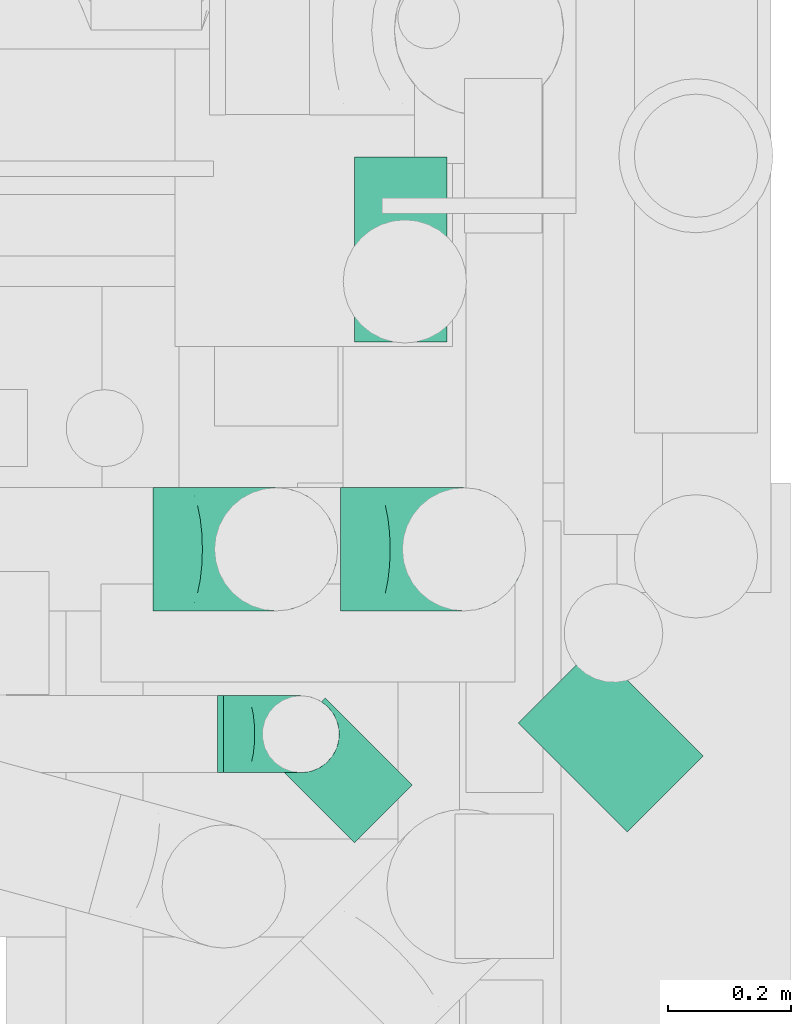
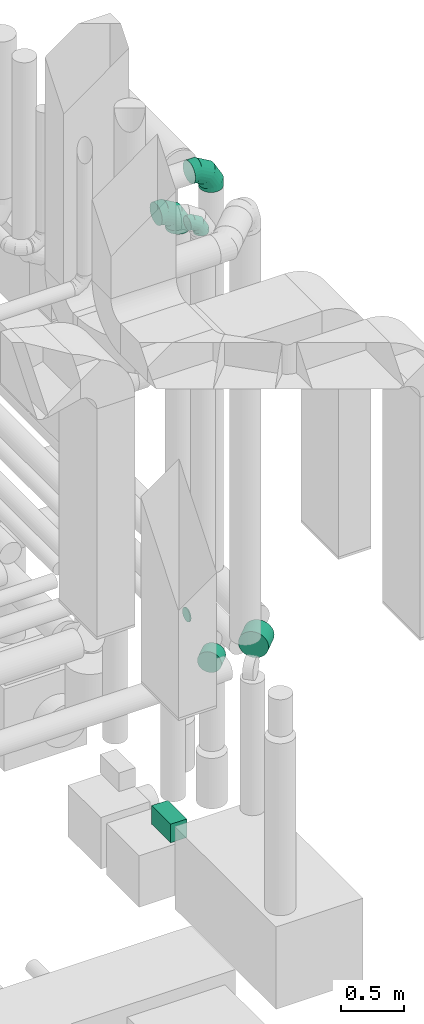
# One storey, part 301 of 337: 4 flow segments, 3 flow fittings.
"""IFC2X3 building model written with IfcOpenShell, lengths in millimetres."""

import ifcopenshell
import ifcopenshell.guid

model = None  # the IFC model being written
_history = None  # IfcOwnerHistory: only IFC2X3 demands one
_inside = {}  # id of a spatial element -> (the spatial element, [elements in it])
_under = {}  # id of a project, library or spatial element -> (it, [spatial elements below it])
_declared = {}  # id of a project -> (the project, [libraries it declares])
_typed = {}  # id of a type object -> (the type object, [elements of that type])
_made_of = {}  # id of a material, layer set ... -> (it, [elements and type objects made of it])


def new_model(schema):
    """Start an empty IFC model of exactly this schema.

    Asked for "IFC4X3", IfcOpenShell would pick the latest addendum, in which some entities
    have other attributes; the version numbers below select the first issue.
    IFC2X3 requires an IfcOwnerHistory on every rooted entity: one is made here for all.
    """
    global model, _history
    if schema == "IFC4X3":
        model = ifcopenshell.file(schema_version=(4, 3, 0, 0))
    else:
        model = ifcopenshell.file(schema=schema)
    _inside.clear()
    _under.clear()
    _declared.clear()
    _typed.clear()
    _made_of.clear()
    _history = None
    if model.schema == "IFC2X3":
        org = make("IfcOrganization", Name="unknown")
        user = make(
            "IfcPersonAndOrganization",
            ThePerson=make("IfcPerson", FamilyName="unknown"),
            TheOrganization=org,
        )
        app = make(
            "IfcApplication",
            ApplicationDeveloper=org,
            Version="unknown",
            ApplicationFullName="unknown",
            ApplicationIdentifier="unknown",
        )
        _history = make(
            "IfcOwnerHistory",
            OwningUser=user,
            OwningApplication=app,
            ChangeAction="ADDED",
            CreationDate=0,
        )
    return model


def make(cls, **values):
    """One entity of the class cls with the attributes given. An attribute that is None is left unset."""
    return model.create_entity(
        cls, **{name: value for name, value in values.items() if value is not None}
    )


def entity(cls, *values):
    """Any entity or typed value of the class cls, its attributes in the order of the schema. None: left unset."""
    e = model.create_entity(cls)
    for i, value in enumerate(values):
        if value is not None:
            e[i] = value
    return e


def rooted(cls, **values):
    """An entity with a GlobalId (a new one), such as an element, a storey or a relation."""
    return make(cls, GlobalId=ifcopenshell.guid.new(), OwnerHistory=_history, **values)


def si_unit(unit_type, name, prefix=None):
    """IfcSIUnit, for example si_unit("LENGTHUNIT", "METRE", prefix="MILLI")."""
    return make("IfcSIUnit", UnitType=unit_type, Prefix=prefix, Name=name)


def converted_unit(unit_type, name, factor, base, dimensions=None, offset=None):
    """IfcConversionBasedUnit, such as the inch: factor (a typed value) times the base unit."""
    return make(
        "IfcConversionBasedUnit"
        if offset is None
        else "IfcConversionBasedUnitWithOffset",
        ConversionOffset=offset,
        Dimensions=None
        if dimensions is None
        else entity("IfcDimensionalExponents", *dimensions),
        UnitType=unit_type,
        Name=name,
        ConversionFactor=make(
            "IfcMeasureWithUnit", ValueComponent=factor, UnitComponent=base
        ),
    )


def derived_unit(unit_type, elements):
    """IfcDerivedUnit: a product of units, each with its exponent."""
    return make(
        "IfcDerivedUnit",
        Elements=[
            make("IfcDerivedUnitElement", Unit=unit, Exponent=power)
            for unit, power in elements
        ],
        UnitType=unit_type,
    )


def assignment(units):
    """IfcUnitAssignment: the units of a project."""
    return None if units is None else make("IfcUnitAssignment", Units=units)


def point(xyz):
    """IfcCartesianPoint."""
    return None if xyz is None else make("IfcCartesianPoint", Coordinates=xyz)


def direction(xyz):
    """IfcDirection."""
    return None if xyz is None else make("IfcDirection", DirectionRatios=xyz)


def frame(location, z_axis=None, x_axis=None):
    """IfcAxis2Placement3D, a coordinate frame: its origin and axes. An axis left out is left unset."""
    return make(
        "IfcAxis2Placement3D",
        Location=point(location),
        Axis=direction(z_axis),
        RefDirection=direction(x_axis),
    )


def frame_2d(location, x_axis=None):
    """IfcAxis2Placement2D, a coordinate frame in the plane: its origin and x axis."""
    return make(
        "IfcAxis2Placement2D", Location=point(location), RefDirection=direction(x_axis)
    )


def origin():
    """The frame at (0, 0, 0) with its axes left unset."""
    return frame((0.0, 0.0, 0.0))


def origin_2d_with_axis():
    """The frame at (0, 0) in the plane with the x axis (1, 0) written out."""
    return frame_2d((0.0, 0.0), x_axis=(1.0, 0.0))


def place(relative_to, where):
    """IfcLocalPlacement: puts the frame where relative to a parent placement (None: the world)."""
    return make(
        "IfcLocalPlacement", PlacementRelTo=relative_to, RelativePlacement=where
    )


def context(
    kind, dimensions, precision=None, world=None, true_north=None, identifier=None
):
    """IfcGeometricRepresentationContext, for example the 3D "Model" context."""
    return make(
        "IfcGeometricRepresentationContext",
        ContextIdentifier=identifier,
        ContextType=kind,
        CoordinateSpaceDimension=dimensions,
        Precision=precision,
        WorldCoordinateSystem=world,
        TrueNorth=true_north,
    )


def subcontext(parent, identifier, kind, view, scale=None):
    """IfcGeometricRepresentationSubContext, for example "Body" below "Model"."""
    return make(
        "IfcGeometricRepresentationSubContext",
        ContextIdentifier=identifier,
        ContextType=kind,
        ParentContext=parent,
        TargetScale=scale,
        TargetView=view,
    )


def project(units=None, contexts=None):
    """IfcProject with its units and contexts."""
    return rooted(
        "IfcProject",
        Name="project",
        RepresentationContexts=contexts,
        UnitsInContext=assignment(units),
    )


def spatial(cls, under=None, at=None, **own):
    """A site, building, storey or space (cls), placed at a placement, below another one or the project."""
    s = rooted(cls, ObjectPlacement=at, **own)
    if under is not None:
        _under.setdefault(under.id(), (under, []))[1].append(s)
    return s


def profile(cls, at=None, kind="AREA", **sizes):
    """A parametric profile (cls). Its sizes go by their IFC names, for example OverallWidth=200.0."""
    return make(cls, ProfileType=kind, Position=at, **sizes)


def rectangle(**sizes):
    """IfcRectangleProfileDef."""
    return profile("IfcRectangleProfileDef", **sizes)


def circle(**sizes):
    """IfcCircleProfileDef."""
    return profile("IfcCircleProfileDef", **sizes)


def extrude(swept, where, along, depth):
    """IfcExtrudedAreaSolid: the profile swept, set in the frame where, extruded along a direction by depth."""
    return make(
        "IfcExtrudedAreaSolid",
        SweptArea=swept,
        Position=where,
        ExtrudedDirection=direction(along),
        Depth=depth,
    )


def faces_of(points, faces, orient=None, outer=None):
    """IfcFace entities. A face is a list of loops; a loop is a list of indices into points, from 0.

    orient and outer hold one flag for each loop. By default every Orientation is true, the
    first loop of a face is its IfcFaceOuterBound and the others are IfcFaceBound.
    """
    made = []
    for i, loops in enumerate(faces):
        bounds = []
        for j, loop in enumerate(loops):
            is_outer = j == 0 if outer is None else outer[i][j]
            bounds.append(
                make(
                    "IfcFaceOuterBound" if is_outer else "IfcFaceBound",
                    Bound=make("IfcPolyLoop", Polygon=[points[k] for k in loop]),
                    Orientation=True if orient is None else orient[i][j],
                )
            )
        made.append(make("IfcFace", Bounds=bounds))
    return made


def faceted_brep(points, faces, orient=None, outer=None, voids=None):
    """IfcFacetedBrep: a solid bounded by flat faces; with voids (closed shells), ...WithVoids."""
    shared = [point(p) for p in points]
    hull = make("IfcClosedShell", CfsFaces=faces_of(shared, faces, orient, outer))
    if voids is None:
        return make("IfcFacetedBrep", Outer=hull)
    return make(
        "IfcFacetedBrepWithVoids",
        Outer=hull,
        Voids=[
            make(cls, CfsFaces=faces_of(shared, fs, o, b)) for cls, fs, o, b in voids
        ],
    )


def shape(context_of_items, identifier, shape_type, items):
    """IfcShapeRepresentation: the items that make up one representation, for example the "Body"."""
    return make(
        "IfcShapeRepresentation",
        ContextOfItems=context_of_items,
        RepresentationIdentifier=identifier,
        RepresentationType=shape_type,
        Items=items,
    )


def source(mapping_origin, context_of_items, identifier, shape_type, items):
    """IfcRepresentationMap: a shape defined once, which mapped items show again and again."""
    return make(
        "IfcRepresentationMap",
        MappingOrigin=mapping_origin,
        MappedRepresentation=shape(context_of_items, identifier, shape_type, items),
    )


def transform(
    local_origin,
    x_axis=None,
    y_axis=None,
    z_axis=None,
    scale=None,
    scale2=None,
    scale3=None,
    uniform=True,
):
    """IfcCartesianTransformationOperator3D, or its non-uniform kind. x_axis, y_axis, z_axis: its Axis1, 2, 3."""
    if uniform:
        return make(
            "IfcCartesianTransformationOperator3D",
            Axis1=direction(x_axis),
            Axis2=direction(y_axis),
            LocalOrigin=point(local_origin),
            Scale=scale,
            Axis3=direction(z_axis),
        )
    return make(
        "IfcCartesianTransformationOperator3DnonUniform",
        Axis1=direction(x_axis),
        Axis2=direction(y_axis),
        LocalOrigin=point(local_origin),
        Scale=scale,
        Axis3=direction(z_axis),
        Scale2=scale2,
        Scale3=scale3,
    )


def mapped(mapping_source, mapping_target):
    """IfcMappedItem: shows the shape of a source again, moved by a transform."""
    return make(
        "IfcMappedItem", MappingSource=mapping_source, MappingTarget=mapping_target
    )


def material(Name=None, Category=None):
    """IfcMaterial."""
    return make("IfcMaterial", Name=Name, Category=Category)


def made_of(thing, what):
    """Note that an element or type object is made of a material, layer set ...; save() writes the relation."""
    if what is not None:
        _made_of.setdefault(what.id(), (what, []))[1].append(thing)
    return thing


def type_object(cls, material=None, **own):
    """A type object (cls), such as IfcWallType, which elements share."""
    return made_of(rooted(cls, **own), material)


def type_shapes(of_type, sources):
    """Give a type object the sources (RepresentationMaps) that its elements show as mapped items."""
    of_type.RepresentationMaps = sources


def element(
    cls,
    number,
    at=None,
    inside=None,
    cuts=None,
    type_object=None,
    material=None,
    context=None,
    identifier="Body",
    shape_type=None,
    held_by="IfcProductDefinitionShape",
    body=None,
    shapes=None,
    **own,
):
    """One element of the class cls, such as IfcWall. Its Tag is "e" and its number.

    at: its placement. inside: the storey or other place that contains it. cuts: it is an
    opening in that element (IfcRelVoidsElement). A single representation is given by context,
    identifier, shape_type and body (its items); several are given by shapes. held_by: the class
    of the entity that holds the representations. save() writes the other relations.
    """
    e = rooted(cls, Tag="e%d" % number, ObjectPlacement=at, **own)
    if body is not None:
        shapes = [shape(context, identifier, shape_type, body)]
    if shapes is not None:
        e.Representation = make(held_by, Representations=shapes)
    if inside is not None:
        _inside.setdefault(inside.id(), (inside, []))[1].append(e)
    if cuts is not None:
        rooted(
            "IfcRelVoidsElement", RelatingBuildingElement=cuts, RelatedOpeningElement=e
        )
    if type_object is not None:
        _typed.setdefault(type_object.id(), (type_object, []))[1].append(e)
    return made_of(e, material)


def aggregate(whole, parts):
    """IfcRelAggregates: a whole, such as a stair, and the parts it consists of."""
    return rooted("IfcRelAggregates", RelatingObject=whole, RelatedObjects=parts)


def save(model, path):
    """Write the relations noted so far, then the file.

    IfcRelAggregates (storeys below a building ...), IfcRelContainedInSpatialStructure (elements
    in a storey), IfcRelDefinesByType, IfcRelAssociatesMaterial and IfcRelDeclares: one each for
    every whole, place, type object, material and project.
    """
    for whole, parts in _under.values():
        aggregate(whole, parts)
    for where, things in _inside.values():
        rooted(
            "IfcRelContainedInSpatialStructure",
            RelatedElements=things,
            RelatingStructure=where,
        )
    for kind, things in _typed.values():
        rooted("IfcRelDefinesByType", RelatedObjects=things, RelatingType=kind)
    for what, things in _made_of.values():
        rooted("IfcRelAssociatesMaterial", RelatedObjects=things, RelatingMaterial=what)
    for by, libraries in _declared.values():
        rooted("IfcRelDeclares", RelatingContext=by, RelatedDefinitions=libraries)
    model.write(path)


model = new_model("IFC2X3")

# Units and contexts
model_context = context("Model", 3, precision=0.01, world=origin(), true_north=direction((6.12303176911189e-17, 1.0)))
body_context = subcontext(model_context, "Body", "Model", "MODEL_VIEW")
ifc_project = project(units=[si_unit("LENGTHUNIT", "METRE", prefix="MILLI"), si_unit("AREAUNIT", "SQUARE_METRE"), si_unit("VOLUMEUNIT", "CUBIC_METRE"), converted_unit("PLANEANGLEUNIT", "DEGREE", entity("IfcRatioMeasure", 0.0174532925199433), si_unit("PLANEANGLEUNIT", "RADIAN"), dimensions=[0, 0, 0, 0, 0, 0, 0]), si_unit("MASSUNIT", "GRAM", prefix="KILO"), derived_unit("MASSDENSITYUNIT", [(si_unit("MASSUNIT", "GRAM", prefix="KILO"), 1), (si_unit("LENGTHUNIT", "METRE"), -3)]), derived_unit("MOMENTOFINERTIAUNIT", [(si_unit("LENGTHUNIT", "METRE"), 4)]), si_unit("TIMEUNIT", "SECOND"), si_unit("FREQUENCYUNIT", "HERTZ"), si_unit("THERMODYNAMICTEMPERATUREUNIT", "DEGREE_CELSIUS"), derived_unit("THERMALTRANSMITTANCEUNIT", [(si_unit("MASSUNIT", "GRAM", prefix="KILO"), 1), (si_unit("THERMODYNAMICTEMPERATUREUNIT", "KELVIN"), -1), (si_unit("TIMEUNIT", "SECOND"), -3)]), derived_unit("VOLUMETRICFLOWRATEUNIT", [(si_unit("LENGTHUNIT", "METRE"), 3), (si_unit("TIMEUNIT", "SECOND"), -1)]), derived_unit("MASSFLOWRATEUNIT", [(si_unit("MASSUNIT", "GRAM", prefix="KILO"), 1), (si_unit("TIMEUNIT", "SECOND"), -1)]), derived_unit("ROTATIONALFREQUENCYUNIT", [(si_unit("TIMEUNIT", "SECOND"), -1)]), si_unit("ELECTRICCURRENTUNIT", "AMPERE"), si_unit("ELECTRICVOLTAGEUNIT", "VOLT"), si_unit("POWERUNIT", "WATT"), si_unit("FORCEUNIT", "NEWTON", prefix="KILO"), si_unit("ILLUMINANCEUNIT", "LUX"), si_unit("LUMINOUSFLUXUNIT", "LUMEN"), si_unit("LUMINOUSINTENSITYUNIT", "CANDELA"), derived_unit("USERDEFINED", [(si_unit("MASSUNIT", "GRAM", prefix="KILO"), -1), (si_unit("LENGTHUNIT", "METRE"), -2), (si_unit("TIMEUNIT", "SECOND"), 3), (si_unit("LUMINOUSFLUXUNIT", "LUMEN"), 1)]), derived_unit("LINEARVELOCITYUNIT", [(si_unit("LENGTHUNIT", "METRE"), 1), (si_unit("TIMEUNIT", "SECOND"), -1)]), si_unit("PRESSUREUNIT", "PASCAL"), derived_unit("USERDEFINED", [(si_unit("LENGTHUNIT", "METRE"), -2), (si_unit("MASSUNIT", "GRAM", prefix="KILO"), 1), (si_unit("TIMEUNIT", "SECOND"), -2)]), derived_unit("LINEARFORCEUNIT", [(si_unit("MASSUNIT", "GRAM", prefix="KILO"), 1), (si_unit("LENGTHUNIT", "METRE"), 1), (si_unit("TIMEUNIT", "SECOND"), -2), (si_unit("LENGTHUNIT", "METRE"), -1)]), derived_unit("PLANARFORCEUNIT", [(si_unit("MASSUNIT", "GRAM", prefix="KILO"), 1), (si_unit("LENGTHUNIT", "METRE"), 1), (si_unit("TIMEUNIT", "SECOND"), -2), (si_unit("LENGTHUNIT", "METRE"), -2)])], contexts=[model_context])

# Site, building, storey
site_placement = place(None, origin())
site = spatial("IfcSite", under=ifc_project, at=site_placement, CompositionType="ELEMENT")
building_placement = place(site_placement, origin())
building = spatial("IfcBuilding", under=site, at=building_placement, CompositionType="ELEMENT")
storey_placement = place(building_placement, origin())
storey = spatial("IfcBuildingStorey", under=building, at=storey_placement, CompositionType="ELEMENT", Elevation=0.0)

# Flow segments
duct_segment_type_1 = type_object("IfcDuctSegmentType", PredefinedType="NOTDEFINED")
flow_segment_1_placement = place(storey_placement, frame((72540.93, 9684.11, 28970.0)))
element("IfcFlowSegment", 1, at=flow_segment_1_placement, inside=storey, type_object=duct_segment_type_1, context=body_context, shape_type="SweptSolid", body=[
    extrude(rectangle(XDim=300.000000000001, YDim=150.000000000001, at=origin_2d_with_axis()), frame((75.0, 150.0, 0.0), z_axis=(0.0, 0.0, 1.0), x_axis=(0.0, 1.0, 0.0)), (0.0, 0.0, 1.0), 180.000000000011),
])
duct_segment_type_2 = type_object("IfcDuctSegmentType", PredefinedType="NOTDEFINED")
flow_segment_2_placement = place(storey_placement, frame((72318.8, 8983.65, 31585.9)))
element("IfcFlowSegment", 2, at=flow_segment_2_placement, inside=storey, type_object=duct_segment_type_2, context=body_context, shape_type="SweptSolid", body=[
    extrude(circle(Radius=62.5, at=origin_2d_with_axis()), frame((0.0, 64.1, 64.1), z_axis=(1.0, 0.0, 0.0), x_axis=(0.0, 1.0, 0.0)), (0.0, 0.0, 1.0), 10.0000000000151),
])
flow_segment_3_placement = place(storey_placement, frame((72397.91, 8869.86, 31098.4)))
element("IfcFlowSegment", 3, at=flow_segment_3_placement, inside=storey, type_object=duct_segment_type_2, context=body_context, shape_type="SweptSolid", body=[
    extrude(circle(Radius=100.0, at=origin_2d_with_axis()), frame((72.31, 72.31, 101.6), z_axis=(0.707106781186654, 0.707106781186441, 0.0), x_axis=(-0.707106781186441, 0.707106781186654, 0.0)), (0.0, 0.0, 1.0), 132.703620410378),
])
flow_segment_4_placement = place(storey_placement, frame((72805.28, 8887.54, 31073.4)))
element("IfcFlowSegment", 4, at=flow_segment_4_placement, inside=storey, type_object=duct_segment_type_2, context=body_context, shape_type="SweptSolid", body=[
    extrude(circle(Radius=125.0, at=origin_2d_with_axis()), frame((89.98, 89.98, 126.6), z_axis=(0.7071067811867, 0.707106781186395, 0.0), x_axis=(-0.707106781186395, 0.7071067811867, 0.0)), (0.0, 0.0, 1.0), 174.407375131986),
])

# Flow fittings
ifc_material = material()
duct_fitting_type_1 = type_object("IfcDuctFittingType", PredefinedType="NOTDEFINED", material=ifc_material)
shared_shape_1 = source(origin(), body_context, "Body", "Brep", [
    faceted_brep([(-200.0, 0.0, -100.0), (-200.0, -25.88, -96.59), (-200.0, -50.0, -86.6), (-200.0, -70.71, -70.71), (-200.0, -86.6, -50.0), (-200.0, -96.59, -25.88), (-200.0, -100.0, 0.0), (-200.0, -96.59, 25.88), (-200.0, -86.6, 50.0), (-200.0, -70.71, 70.71), (-200.0, -50.0, 86.6), (-200.0, -25.88, 96.59), (-200.0, 0.0, 100.0), (-200.0, 25.88, 96.59), (-200.0, 50.0, 86.6), (-200.0, 70.71, 70.71), (-200.0, 86.6, 50.0), (-200.0, 96.59, 25.88), (-200.0, 100.0, 0.0), (-200.0, 96.59, -25.88), (-200.0, 86.6, -50.0), (-200.0, 70.71, -70.71), (-200.0, 50.0, -86.6), (-200.0, 25.88, -96.59), (-153.35, 25.88, 96.59), (-159.81, 50.0, 86.6), (-146.41, 0.0, 100.0), (-165.36, 70.71, 70.71), (-172.29, 96.59, 25.88), (-173.21, 100.0, 0.0), (-169.62, 86.6, 50.0), (-169.62, 86.6, -50.0), (-165.36, 70.71, -70.71), (-172.29, 96.59, -25.88), (-153.35, 25.88, -96.59), (-146.41, 0.0, -100.0), (-159.81, 50.0, -86.6), (-139.48, -25.88, -96.59), (-133.01, -50.0, -86.6), (-127.46, -70.71, -70.71), (-123.21, -86.6, -50.0), (-120.53, -96.59, -25.88), (-119.62, -100.0, 0.0), (-120.53, -96.59, 25.88), (-123.21, -86.6, 50.0), (-127.46, -70.71, 70.71), (-133.01, -50.0, 86.6), (-139.48, -25.88, 96.59), (-72.54, 72.54, 96.59), (-90.19, 90.19, 86.6), (-53.59, 53.59, 100.0), (-105.35, 105.35, 70.71), (-116.99, 116.99, 50.0), (-124.3, 124.3, 25.88), (-126.79, 126.79, 0.0), (-124.3, 124.3, -25.88), (-116.99, 116.99, -50.0), (-105.35, 105.35, -70.71), (-72.54, 72.54, -96.59), (-53.59, 53.59, -100.0), (-90.19, 90.19, -86.6), (-34.64, 34.64, -96.59), (-16.99, 16.99, -86.6), (-1.83, 1.83, -70.71), (9.81, -9.81, -50.0), (17.12, -17.12, -25.88), (19.62, -19.62, 0.0), (17.12, -17.12, 25.88), (9.81, -9.81, 50.0), (-1.83, 1.83, 70.71), (-16.99, 16.99, 86.6), (-34.64, 34.64, 96.59), (-25.88, 153.35, 96.59), (-50.0, 159.81, 86.6), (0.0, 146.41, 100.0), (-70.71, 165.36, 70.71), (-86.6, 169.62, 50.0), (-96.59, 172.29, 25.88), (-100.0, 173.21, 0.0), (-96.59, 172.29, -25.88), (-86.6, 169.62, -50.0), (-70.71, 165.36, -70.71), (-25.88, 153.35, -96.59), (0.0, 146.41, -100.0), (-50.0, 159.81, -86.6), (25.88, 139.48, -96.59), (50.0, 133.01, -86.6), (70.71, 127.46, -70.71), (86.6, 123.21, -50.0), (96.59, 120.53, -25.88), (100.0, 119.62, 0.0), (96.59, 120.53, 25.88), (86.6, 123.21, 50.0), (70.71, 127.46, 70.71), (50.0, 133.01, 86.6), (25.88, 139.48, 96.59), (-25.88, 200.0, -96.59), (-50.0, 200.0, -86.6), (-70.71, 200.0, -70.71), (-86.6, 200.0, -50.0), (-96.59, 200.0, -25.88), (-100.0, 200.0, 0.0), (-96.59, 200.0, 25.88), (-86.6, 200.0, 50.0), (-70.71, 200.0, 70.71), (-50.0, 200.0, 86.6), (-25.88, 200.0, 96.59), (0.0, 200.0, 100.0), (25.88, 200.0, 96.59), (50.0, 200.0, 86.6), (70.71, 200.0, 70.71), (86.6, 200.0, 50.0), (96.59, 200.0, 25.88), (100.0, 200.0, 0.0), (96.59, 200.0, -25.88), (86.6, 200.0, -50.0), (70.71, 200.0, -70.71), (50.0, 200.0, -86.6), (25.88, 200.0, -96.59), (0.0, 200.0, -100.0)], [[[0, 1, 2, 3, 4, 5, 6, 7, 8, 9, 10, 11, 12, 13, 14, 15, 16, 17, 18, 19, 20, 21, 22, 23]], [[24, 25, 14, 13]], [[26, 24, 13, 12]], [[14, 25, 27, 15]], [[28, 29, 18, 17]], [[30, 28, 17, 16]], [[15, 27, 30, 16]], [[20, 31, 32, 21]], [[33, 31, 20, 19]], [[18, 29, 33, 19]], [[34, 35, 0, 23]], [[36, 34, 23, 22]], [[32, 36, 22, 21]], [[1, 0, 35, 37]], [[2, 1, 37, 38]], [[38, 39, 3, 2]], [[5, 4, 40, 41]], [[6, 5, 41, 42]], [[39, 40, 4, 3]], [[6, 42, 43, 7]], [[7, 43, 44, 8]], [[8, 44, 45, 9]], [[9, 45, 46, 10]], [[10, 46, 47, 11]], [[26, 12, 11, 47]], [[48, 49, 25, 24]], [[50, 48, 24, 26]], [[27, 25, 49, 51]], [[52, 53, 28, 30]], [[51, 52, 30, 27]], [[29, 28, 53, 54]], [[55, 56, 31, 33]], [[54, 55, 33, 29]], [[32, 31, 56, 57]], [[58, 59, 35, 34]], [[60, 58, 34, 36]], [[57, 60, 36, 32]], [[37, 35, 59, 61]], [[38, 37, 61, 62]], [[39, 38, 62, 63]], [[41, 40, 64, 65]], [[42, 41, 65, 66]], [[63, 64, 40, 39]], [[43, 42, 66, 67]], [[44, 43, 67, 68]], [[68, 69, 45, 44]], [[46, 45, 69, 70]], [[47, 46, 70, 71]], [[26, 47, 71, 50]], [[72, 73, 49, 48]], [[74, 72, 48, 50]], [[51, 49, 73, 75]], [[76, 77, 53, 52]], [[75, 76, 52, 51]], [[54, 53, 77, 78]], [[79, 80, 56, 55]], [[78, 79, 55, 54]], [[57, 56, 80, 81]], [[82, 83, 59, 58]], [[84, 82, 58, 60]], [[81, 84, 60, 57]], [[61, 59, 83, 85]], [[62, 61, 85, 86]], [[63, 62, 86, 87]], [[65, 64, 88, 89]], [[66, 65, 89, 90]], [[87, 88, 64, 63]], [[67, 66, 90, 91]], [[68, 67, 91, 92]], [[92, 93, 69, 68]], [[70, 69, 93, 94]], [[71, 70, 94, 95]], [[50, 71, 95, 74]], [[96, 97, 98, 99, 100, 101, 102, 103, 104, 105, 106, 107, 108, 109, 110, 111, 112, 113, 114, 115, 116, 117, 118, 119]], [[72, 74, 107, 106]], [[73, 72, 106, 105]], [[75, 73, 105, 104]], [[102, 101, 78, 77]], [[103, 102, 77, 76]], [[75, 104, 103, 76]], [[78, 101, 100, 79]], [[79, 100, 99, 80]], [[80, 99, 98, 81]], [[84, 97, 96, 82]], [[82, 96, 119, 83]], [[84, 81, 98, 97]], [[118, 117, 86, 85]], [[119, 118, 85, 83]], [[116, 87, 86, 117]], [[88, 115, 114, 89]], [[89, 114, 113, 90]], [[115, 88, 87, 116]], [[91, 90, 113, 112]], [[92, 91, 112, 111]], [[111, 110, 93, 92]], [[95, 94, 109, 108]], [[74, 95, 108, 107]], [[110, 109, 94, 93]]]),
])
type_shapes(duct_fitting_type_1, [shared_shape_1])
for number, where, z_axis, x_axis in (
    (5, (72718.49, 9347.75, 35700.0), (0.0, -1.0, 0.0), (0.0, 0.0, 1.0)),
    (6, (72413.8, 9347.75, 35400.0), (0.0, -1.0, 0.0), (0.0, 0.0, 1.0)),
):
    element("IfcFlowFitting", number, at=place(storey_placement, frame(where, z_axis=z_axis, x_axis=x_axis)), inside=storey, type_object=duct_fitting_type_1, material=ifc_material, context=body_context, shape_type="MappedRepresentation", body=[
        mapped(shared_shape_1, transform((0.0, 0.0, 0.0), scale=1.0)),
    ])
duct_fitting_type_2 = type_object("IfcDuctFittingType", PredefinedType="NOTDEFINED", material=ifc_material)
shared_shape_2 = source(origin(), body_context, "Body", "Brep", [
    faceted_brep([(-125.0, 0.0, -62.5), (-125.0, -16.18, -60.37), (-125.0, -31.25, -54.13), (-125.0, -44.19, -44.19), (-125.0, -54.13, -31.25), (-125.0, -60.37, -16.18), (-125.0, -62.5, 0.0), (-125.0, -60.37, 16.18), (-125.0, -54.13, 31.25), (-125.0, -44.19, 44.19), (-125.0, -31.25, 54.13), (-125.0, -16.18, 60.37), (-125.0, 0.0, 62.5), (-125.0, 16.18, 60.37), (-125.0, 31.25, 54.13), (-125.0, 44.19, 44.19), (-125.0, 54.13, 31.25), (-125.0, 60.37, 16.18), (-125.0, 62.5, 0.0), (-125.0, 60.37, -16.18), (-125.0, 54.13, -31.25), (-125.0, 44.19, -44.19), (-125.0, 31.25, -54.13), (-125.0, 16.18, -60.37), (-95.84, 16.18, 60.37), (-99.88, 31.25, 54.13), (-91.51, 0.0, 62.5), (-103.35, 44.19, 44.19), (-107.68, 60.37, 16.18), (-108.25, 62.5, 0.0), (-106.01, 54.13, 31.25), (-106.01, 54.13, -31.25), (-103.35, 44.19, -44.19), (-107.68, 60.37, -16.18), (-95.84, 16.18, -60.37), (-91.51, 0.0, -62.5), (-99.88, 31.25, -54.13), (-87.17, -16.18, -60.37), (-83.13, -31.25, -54.13), (-79.66, -44.19, -44.19), (-77.0, -54.13, -31.25), (-75.33, -60.37, -16.18), (-74.76, -62.5, 0.0), (-75.33, -60.37, 16.18), (-77.0, -54.13, 31.25), (-79.66, -44.19, 44.19), (-83.13, -31.25, 54.13), (-87.17, -16.18, 60.37), (-45.34, 45.34, 60.37), (-56.37, 56.37, 54.13), (-33.49, 33.49, 62.5), (-65.85, 65.85, 44.19), (-73.12, 73.12, 31.25), (-77.69, 77.69, 16.18), (-79.25, 79.25, 0.0), (-77.69, 77.69, -16.18), (-73.12, 73.12, -31.25), (-65.85, 65.85, -44.19), (-45.34, 45.34, -60.37), (-33.49, 33.49, -62.5), (-56.37, 56.37, -54.13), (-21.65, 21.65, -60.37), (-10.62, 10.62, -54.13), (-1.14, 1.14, -44.19), (6.13, -6.13, -31.25), (10.7, -10.7, -16.18), (12.26, -12.26, 0.0), (10.7, -10.7, 16.18), (6.13, -6.13, 31.25), (-1.14, 1.14, 44.19), (-10.62, 10.62, 54.13), (-21.65, 21.65, 60.37), (-16.18, 95.84, 60.37), (-31.25, 99.88, 54.13), (0.0, 91.51, 62.5), (-44.19, 103.35, 44.19), (-54.13, 106.01, 31.25), (-60.37, 107.68, 16.18), (-62.5, 108.25, 0.0), (-60.37, 107.68, -16.18), (-54.13, 106.01, -31.25), (-44.19, 103.35, -44.19), (-16.18, 95.84, -60.37), (0.0, 91.51, -62.5), (-31.25, 99.88, -54.13), (16.18, 87.17, -60.37), (31.25, 83.13, -54.13), (44.19, 79.66, -44.19), (54.13, 77.0, -31.25), (60.37, 75.33, -16.18), (62.5, 74.76, 0.0), (60.37, 75.33, 16.18), (54.13, 77.0, 31.25), (44.19, 79.66, 44.19), (31.25, 83.13, 54.13), (16.18, 87.17, 60.37), (-16.18, 125.0, -60.37), (-31.25, 125.0, -54.13), (-44.19, 125.0, -44.19), (-54.13, 125.0, -31.25), (-60.37, 125.0, -16.18), (-62.5, 125.0, 0.0), (-60.37, 125.0, 16.18), (-54.13, 125.0, 31.25), (-44.19, 125.0, 44.19), (-31.25, 125.0, 54.13), (-16.18, 125.0, 60.37), (0.0, 125.0, 62.5), (16.18, 125.0, 60.37), (31.25, 125.0, 54.13), (44.19, 125.0, 44.19), (54.13, 125.0, 31.25), (60.37, 125.0, 16.18), (62.5, 125.0, 0.0), (60.37, 125.0, -16.18), (54.13, 125.0, -31.25), (44.19, 125.0, -44.19), (31.25, 125.0, -54.13), (16.18, 125.0, -60.37), (0.0, 125.0, -62.5)], [[[0, 1, 2, 3, 4, 5, 6, 7, 8, 9, 10, 11, 12, 13, 14, 15, 16, 17, 18, 19, 20, 21, 22, 23]], [[24, 25, 14, 13]], [[26, 24, 13, 12]], [[14, 25, 27, 15]], [[28, 29, 18, 17]], [[30, 28, 17, 16]], [[15, 27, 30, 16]], [[20, 31, 32, 21]], [[33, 31, 20, 19]], [[18, 29, 33, 19]], [[34, 35, 0, 23]], [[36, 34, 23, 22]], [[21, 32, 36, 22]], [[1, 0, 35, 37]], [[2, 1, 37, 38]], [[38, 39, 3, 2]], [[5, 4, 40, 41]], [[6, 5, 41, 42]], [[39, 40, 4, 3]], [[6, 42, 43, 7]], [[7, 43, 44, 8]], [[45, 9, 8, 44]], [[9, 45, 46, 10]], [[10, 46, 47, 11]], [[26, 12, 11, 47]], [[48, 49, 25, 24]], [[50, 48, 24, 26]], [[27, 25, 49, 51]], [[52, 53, 28, 30]], [[51, 52, 30, 27]], [[29, 28, 53, 54]], [[55, 56, 31, 33]], [[54, 55, 33, 29]], [[57, 32, 31, 56]], [[58, 59, 35, 34]], [[60, 58, 34, 36]], [[57, 60, 36, 32]], [[37, 35, 59, 61]], [[38, 37, 61, 62]], [[39, 38, 62, 63]], [[41, 40, 64, 65]], [[42, 41, 65, 66]], [[63, 64, 40, 39]], [[43, 42, 66, 67]], [[44, 43, 67, 68]], [[68, 69, 45, 44]], [[46, 45, 69, 70]], [[47, 46, 70, 71]], [[26, 47, 71, 50]], [[72, 73, 49, 48]], [[74, 72, 48, 50]], [[51, 49, 73, 75]], [[76, 77, 53, 52]], [[75, 76, 52, 51]], [[54, 53, 77, 78]], [[79, 80, 56, 55]], [[78, 79, 55, 54]], [[81, 57, 56, 80]], [[82, 83, 59, 58]], [[84, 82, 58, 60]], [[81, 84, 60, 57]], [[61, 59, 83, 85]], [[62, 61, 85, 86]], [[63, 62, 86, 87]], [[65, 64, 88, 89]], [[66, 65, 89, 90]], [[87, 88, 64, 63]], [[67, 66, 90, 91]], [[68, 67, 91, 92]], [[92, 93, 69, 68]], [[70, 69, 93, 94]], [[71, 70, 94, 95]], [[50, 71, 95, 74]], [[96, 97, 98, 99, 100, 101, 102, 103, 104, 105, 106, 107, 108, 109, 110, 111, 112, 113, 114, 115, 116, 117, 118, 119]], [[72, 74, 107, 106]], [[73, 72, 106, 105]], [[75, 73, 105, 104]], [[77, 76, 103, 102]], [[78, 77, 102, 101]], [[75, 104, 103, 76]], [[78, 101, 100, 79]], [[79, 100, 99, 80]], [[80, 99, 98, 81]], [[96, 119, 83, 82]], [[97, 96, 82, 84]], [[84, 81, 98, 97]], [[83, 119, 118, 85]], [[85, 118, 117, 86]], [[116, 87, 86, 117]], [[88, 115, 114, 89]], [[89, 114, 113, 90]], [[115, 88, 87, 116]], [[91, 90, 113, 112]], [[92, 91, 112, 111]], [[111, 110, 93, 92]], [[95, 94, 109, 108]], [[74, 95, 108, 107]], [[110, 109, 94, 93]]]),
])
type_shapes(duct_fitting_type_2, [shared_shape_2])
flow_fitting_placement = place(storey_placement, frame((72453.8, 9047.75, 35450.0), z_axis=(0.0, -1.0, 0.0), x_axis=(0.0, 0.0, 1.0)))
element("IfcFlowFitting", 7, at=flow_fitting_placement, inside=storey, type_object=duct_fitting_type_2, material=ifc_material, context=body_context, shape_type="MappedRepresentation", body=[
    mapped(shared_shape_2, transform((0.0, 0.0, 0.0), scale=1.0)),
])

save(model, "model.ifc")
